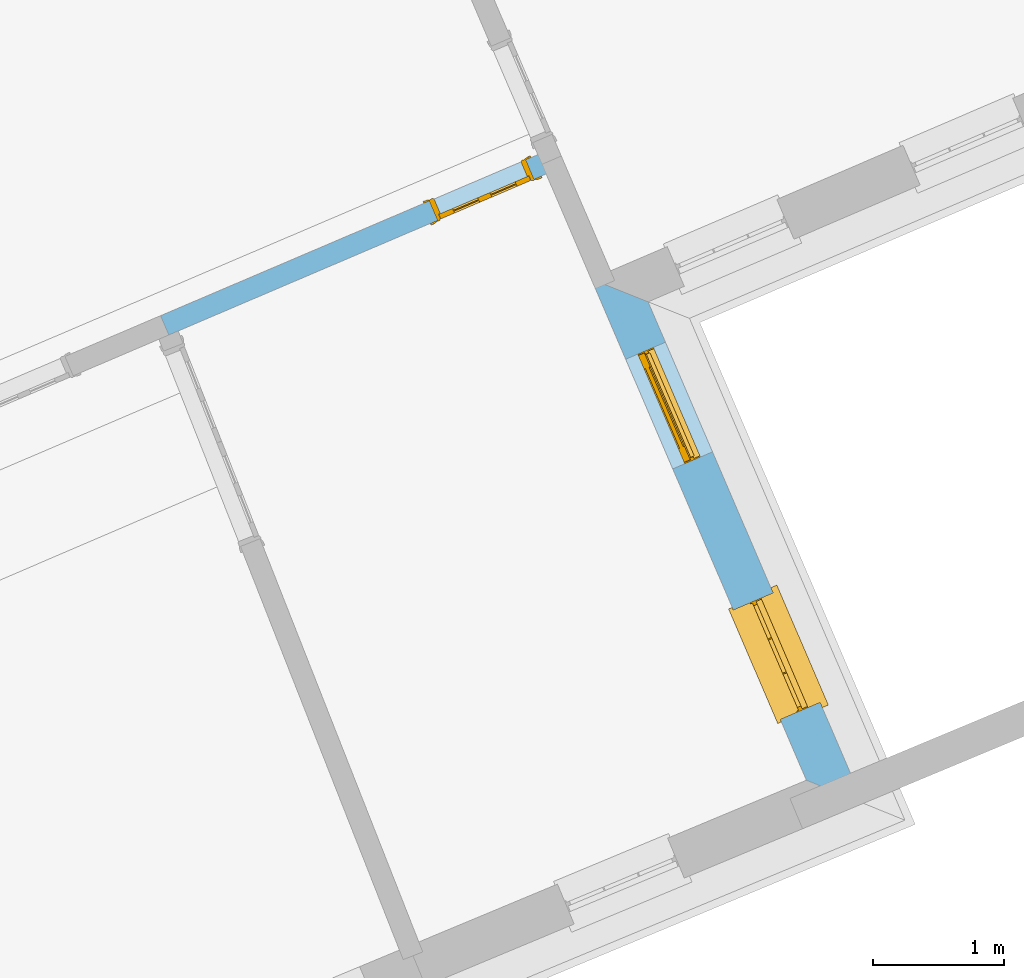
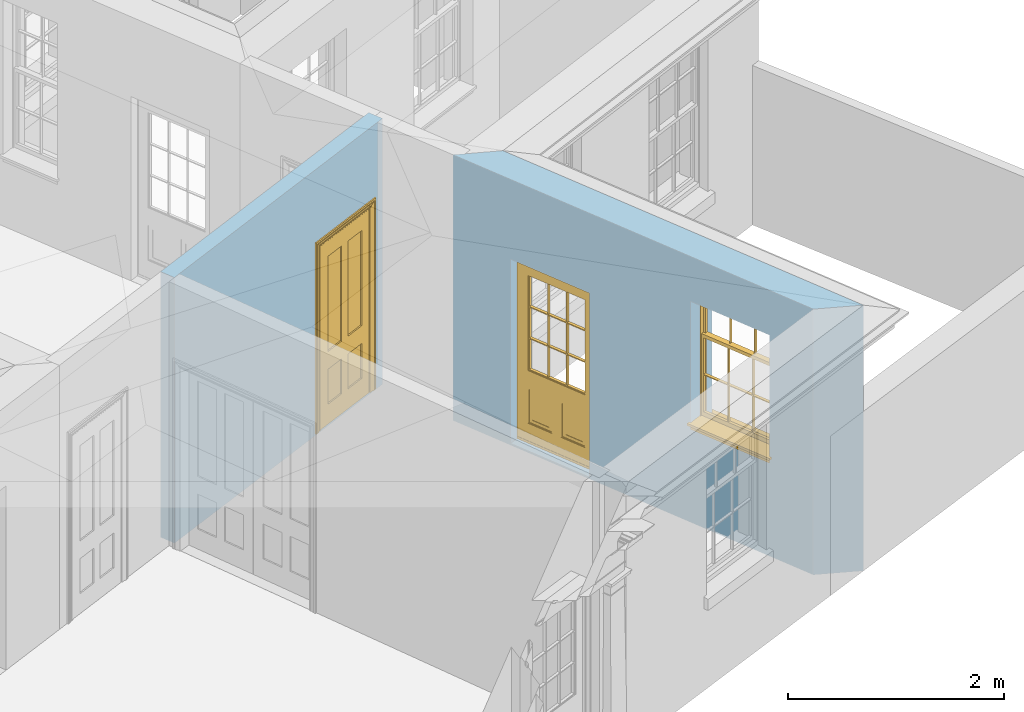
# One storey, part 8 of 19: 2 doors, 1 window, 3 openings, plus 2 elements that do not belong to this part.
"""IFC2X3 building model written with IfcOpenShell, lengths in metres."""

from ifc_helpers import new_model, si_unit, frame, origin, place, context, subcontext, project, spatial, polyline, outline, extrude, faceted_brep, material, layer, layer_set, layer_usage, element, fill, save


model = new_model("IFC2X3")

# Units and contexts
model_context = context("Model", 3, world=origin())
body_context = subcontext(model_context, "Body", "Model", "MODEL_VIEW")
ifc_project = project(units=[si_unit("PLANEANGLEUNIT", "RADIAN"), si_unit("MASSUNIT", "GRAM", prefix="KILO"), si_unit("FORCEUNIT", "NEWTON", prefix="KILO"), si_unit("LENGTHUNIT", "METRE")], contexts=[model_context])

# Site, building, storey
site_placement = place(None, origin())
site = spatial("IfcSite", under=ifc_project, at=site_placement, CompositionType="ELEMENT")
building_placement = place(None, origin())
building = spatial("IfcBuilding", under=site, at=building_placement, Name="Building plot-0", CompositionType="ELEMENT")
storey_placement = place(None, origin())
storey = spatial("IfcBuildingStorey", under=building, at=storey_placement, Name="Floor 0", CompositionType="ELEMENT", Elevation=0.0)

# Wall, openings, window, door
ifc_material_1 = material(Name="Masonry")
ifc_layer_1 = layer(ifc_material_1, 0.33, ventilated=False)
ifc_layer_set_1 = layer_set([ifc_layer_1], Name="My Wall")
ifc_layer_usage_1 = layer_usage(ifc_layer_set_1, "AXIS2", "NEGATIVE", 0.08)
wall_1_placement = place(storey_placement, origin())
wall_1 = element("IfcWallStandardCase", 1, at=wall_1_placement, inside=storey, material=ifc_layer_usage_1, Name="exterior", context=body_context, shape_type="SweptSolid", body=[
    extrude(outline(polyline([(24.2038471452139, 23.8554175583724), (24.6386025500617, 23.6792480885884), (22.9972229109118, 27.5025826875291), (22.5638042639667, 27.6756383909319), (24.2038471452139, 23.8554175583724)])), origin(), (0.0, 0.0, 1.0), 3.0),
])
opening_1_placement = place(storey_placement, frame((0.0, 0.0, 1.05)))
opening_1 = element("IfcOpeningElement", 2, at=opening_1_placement, cuts=wall_1, Name="Opening", ObjectType="Opening", context=body_context, shape_type="SweptSolid", body=[
    extrude(outline(polyline([(24.3083684269602, 24.4484763149473), (23.9493831563184, 25.2846757980027), (23.6461459811444, 25.1544943262315), (24.0051312517862, 24.3182948431761), (24.3083684269602, 24.4484763149473)])), origin(), (0.0, 0.0, 1.0), 1.445),
])
opening_2_placement = place(storey_placement, frame((0.0, 0.0, 0.02)))
opening_2 = element("IfcOpeningElement", 3, at=opening_2_placement, cuts=wall_1, Name="Opening", ObjectType="Opening", context=body_context, shape_type="SweptSolid", body=[
    extrude(outline(polyline([(23.4881849550756, 26.3589641574551), (23.1291996844338, 27.1951636405105), (22.8259625092599, 27.0649821687393), (23.1849477799017, 26.2287826856839), (23.4881849550756, 26.3589641574551)])), origin(), (0.0, 0.0, 1.0), 2.08),
])
window_placement = place(storey_placement, frame((24.0786432942526, 24.3498539878479, 1.05), z_axis=(0.0, 0.0, 1.0), x_axis=(-0.358985270641785, 0.836199483055474, 0.0)))
window = element("IfcWindow", 4, at=window_placement, inside=storey, Name="kitchen outside window", OverallHeight=1.445, OverallWidth=0.91, context=body_context, shape_type="Brep", held_by="IfcProductRepresentation", body=[
    faceted_brep([(0.876875, -0.105, 0.999097), (0.876875, -0.105, 1.411875), (0.9, -0.105, 1.435), (0.033125, -0.105, 1.411875), (0.033125, -0.105, 0.999097), (0.01, -0.105, 1.435), (0.033125, -0.135, 1.411875), (0.01, -0.135, 1.435), (0.033125, -0.135, 0.999097), (0.876875, -0.135, 1.411875), (0.876875, -0.135, 0.999097), (0.9, -0.135, 1.435), (0.033125, -0.105, 0.960972), (0.01, -0.105, 0.960972), (0.033125, -0.105, 0.548195), (0.876875, -0.105, 0.960972), (0.876875, -0.105, 0.548195), (0.9, -0.105, 0.960972), (0.876875, -0.105, 0.538195), (0.876875, -0.105, 0.125417), (0.9, -0.105, 0.077167), (0.033125, -0.105, 0.125417), (0.033125, -0.105, 0.538195), (0.01, -0.105, 0.077167), (0.9, -0.135, 0.960972), (0.01, -0.135, 0.960972), (-0.0425, -0.25, 0.01), (-0.0425, -0.3, 0.001667), (0.0, -0.25, 0.01), (0.9525, -0.25, 0.01), (0.91, -0.25, 0.01), (0.9525, -0.3, 0.001667), (-0.02, 0.08, 0.077167), (0.0, 0.08, 0.077167), (-0.02, 0.11, 0.077167), (0.0, -0.06, 0.077167), (0.01, -0.06, 0.077167), (0.91, -0.06, 0.077167), (0.91, 0.08, 0.077167), (0.9, -0.06, 0.077167), (0.93, 0.08, 0.077167), (0.93, 0.11, 0.077167), (0.01, -0.105, 0.999097), (0.01, -0.075, 0.999097), (0.9, -0.105, 0.999097), (0.9, -0.075, 0.999097), (0.876875, -0.075, 0.125417), (0.876875, -0.075, 0.538195), (0.9, -0.075, 0.077167), (0.876875, -0.075, 0.548195), (0.876875, -0.075, 0.960972), (0.033125, -0.075, 0.125417), (0.01, -0.075, 0.077167), (0.033125, -0.075, 0.538195), (0.033125, -0.075, 0.960972), (0.033125, -0.075, 0.548195), (-0.02, 0.08, 0.052167), (-0.02, 0.11, 0.052167), (0.93, 0.11, 0.052167), (0.93, 0.08, 0.052167), (0.91, 0.08, 0.052167), (0.0, 0.08, 0.052167), (0.91, -0.15, 0.026667), (0.0, -0.15, 0.026667), (-0.0425, -0.3, -0.123333), (0.9525, -0.3, -0.123333), (-0.0425, -0.25, -0.123333), (0.9525, -0.25, -0.123333), (0.01, -0.06, 1.435), (0.9, -0.06, 1.435), (0.0, -0.06, 1.445), (0.91, -0.06, 1.445), (0.01, -0.15, 0.077167), (0.9, -0.15, 0.077167), (0.592292, -0.105, 0.125417), (0.592292, -0.075, 0.125417), (0.317708, -0.075, 0.125417), (0.317708, -0.105, 0.125417), (0.592292, -0.105, 0.548195), (0.317708, -0.105, 0.548195), (0.317708, -0.105, 0.538195), (0.592292, -0.105, 0.538195), (0.592292, -0.075, 0.548195), (0.317708, -0.075, 0.548195), (0.602292, -0.075, 0.548195), (0.602292, -0.105, 0.548195), (0.317708, -0.075, 0.538195), (0.307708, -0.075, 0.125417), (0.307708, -0.075, 0.538195), (0.602292, -0.075, 0.538195), (0.602292, -0.075, 0.125417), (0.592292, -0.075, 0.538195), (0.307708, -0.075, 0.548195), (0.317708, -0.075, 0.960972), (0.307708, -0.075, 0.960972), (0.602292, -0.075, 0.960972), (0.592292, -0.075, 0.960972), (0.307708, -0.105, 0.538195), (0.307708, -0.105, 0.125417), (0.307708, -0.105, 0.548195), (0.307708, -0.105, 0.960972), (0.592292, -0.105, 0.960972), (0.317708, -0.105, 0.960972), (0.602292, -0.105, 0.960972), (0.602292, -0.105, 0.538195), (0.602292, -0.105, 0.125417), (0.317708, -0.135, 1.411875), (0.307708, -0.135, 1.411875), (0.307708, -0.135, 0.999097), (0.317708, -0.135, 0.999097), (0.602292, -0.135, 1.411875), (0.592292, -0.135, 1.411875), (0.592292, -0.135, 0.999097), (0.602292, -0.135, 0.999097), (0.317708, -0.105, 0.999097), (0.307708, -0.105, 0.999097), (0.307708, -0.105, 1.411875), (0.317708, -0.105, 1.411875), (0.602292, -0.105, 0.999097), (0.592292, -0.105, 0.999097), (0.592292, -0.105, 1.411875), (0.602292, -0.105, 1.411875), (0.91, -0.15, 1.445), (0.9, -0.15, 1.435), (0.01, -0.15, 1.435), (0.0, -0.15, 1.445), (0.91, -0.25, 0.0), (0.0, -0.25, 0.0), (0.91, 0.08, 0.0), (0.0, 0.08, 0.0)], [[[0, 1, 2]], [[3, 4, 5]], [[6, 7, 8]], [[9, 10, 11]], [[12, 13, 14]], [[15, 16, 17]], [[18, 19, 20]], [[21, 22, 23]], [[24, 15, 17]], [[13, 12, 25]], [[26, 27, 28]], [[29, 30, 31]], [[32, 33, 34]], [[35, 36, 33]], [[37, 38, 39]], [[40, 41, 38]], [[42, 4, 43]], [[44, 45, 0]], [[46, 47, 48]], [[49, 50, 45]], [[51, 52, 53]], [[54, 55, 43]], [[38, 33, 36, 39]], [[41, 34, 33, 38]], [[56, 32, 34, 57]], [[57, 34, 41, 58]], [[58, 41, 40, 59]], [[57, 58, 60, 61]], [[52, 48, 39, 36]], [[62, 63, 28, 30]], [[27, 31, 30, 28]], [[27, 64, 65, 31]], [[66, 67, 65, 64]], [[2, 5, 68, 69]], [[68, 70, 71, 69]], [[20, 23, 72, 73]], [[73, 72, 63, 62]], [[74, 75, 76, 77]], [[78, 79, 80, 81]], [[78, 82, 83, 79]], [[16, 49, 84, 85]], [[86, 76, 87, 88]], [[89, 90, 75, 91]], [[92, 88, 53, 55]], [[82, 91, 86, 83]], [[93, 83, 92, 94]], [[95, 84, 82, 96]], [[89, 84, 49, 47]], [[97, 88, 87, 98]], [[22, 53, 88, 97]], [[81, 91, 75, 74]], [[80, 86, 91, 81]], [[77, 76, 86, 80]], [[99, 92, 55, 14]], [[100, 94, 92, 99]], [[101, 96, 82, 78]], [[79, 83, 93, 102]], [[85, 84, 95, 103]], [[104, 89, 47, 18]], [[105, 90, 89, 104]], [[104, 18, 16, 85]], [[80, 97, 98, 77]], [[104, 81, 74, 105]], [[103, 101, 78, 85]], [[99, 14, 22, 97]], [[102, 100, 99, 79]], [[106, 107, 108, 109]], [[110, 111, 112, 113]], [[114, 115, 116, 117]], [[118, 119, 120, 121]], [[107, 116, 115, 108]], [[111, 120, 119, 112]], [[109, 114, 117, 106]], [[113, 118, 121, 110]], [[85, 78, 81, 104]], [[84, 89, 91, 82]], [[83, 86, 88, 92]], [[79, 99, 97, 80]], [[109, 112, 119, 114]], [[102, 93, 96, 101]], [[106, 117, 120, 111]], [[98, 87, 51, 21]], [[6, 3, 116, 107]], [[110, 121, 1, 9]], [[19, 46, 90, 105]], [[26, 66, 64, 27]], [[29, 31, 65, 67]], [[25, 24, 112, 109]], [[11, 7, 106, 111]], [[75, 48, 52, 76]], [[43, 45, 96, 93]], [[45, 43, 114, 119]], [[5, 2, 120, 117]], [[24, 25, 102, 101]], [[42, 5, 4]], [[2, 44, 0]], [[49, 45, 48, 47]], [[52, 43, 55, 53]], [[14, 13, 23, 22]], [[20, 17, 16, 18]], [[24, 11, 10]], [[25, 8, 7]], [[8, 4, 3, 6]], [[9, 1, 0, 10]], [[15, 50, 49, 16]], [[18, 47, 46, 19]], [[21, 51, 53, 22]], [[14, 55, 54, 12]], [[44, 2, 69, 45]], [[68, 5, 42, 43]], [[36, 35, 70, 68]], [[39, 69, 71, 37]], [[62, 122, 123, 73]], [[63, 72, 124, 125]], [[8, 108, 115, 4]], [[113, 10, 0, 118]], [[94, 100, 12, 54]], [[17, 20, 73, 24]], [[72, 23, 13, 25]], [[52, 36, 68, 43]], [[69, 39, 48, 45]], [[11, 24, 73, 123]], [[7, 124, 72, 25]], [[23, 77, 98]], [[98, 21, 23]], [[105, 74, 20]], [[20, 19, 105]], [[20, 74, 77, 23]], [[113, 112, 24]], [[24, 10, 113]], [[25, 109, 108]], [[108, 8, 25]], [[110, 9, 11]], [[11, 111, 110]], [[7, 6, 107]], [[107, 106, 7]], [[5, 117, 116]], [[116, 3, 5]], [[121, 120, 2]], [[2, 1, 121]], [[11, 123, 124, 7]], [[122, 125, 124, 123]], [[43, 93, 94]], [[94, 54, 43]], [[96, 45, 95]], [[50, 95, 45]], [[15, 103, 95, 50]], [[48, 75, 90]], [[90, 46, 48]], [[87, 76, 52]], [[52, 51, 87]], [[103, 15, 24]], [[24, 101, 103]], [[100, 102, 25]], [[25, 12, 100]], [[115, 114, 43]], [[43, 4, 115]], [[118, 0, 45]], [[45, 119, 118]], [[71, 70, 125, 122]], [[70, 35, 63, 125]], [[122, 62, 37, 71]], [[126, 67, 66, 127]], [[60, 58, 59]], [[38, 60, 59, 40]], [[61, 56, 57]], [[32, 56, 61, 33]], [[61, 60, 128, 129]], [[62, 60, 38, 37]], [[126, 128, 60, 62]], [[33, 61, 63, 35]], [[61, 129, 127, 63]], [[128, 126, 127, 129]], [[28, 127, 66, 26]], [[63, 127, 28]], [[29, 67, 126, 30]], [[30, 126, 62]]]),
])
fill(opening_1, window)
door_1_placement = place(storey_placement, frame((23.2584598223681, 26.2603418303557, 0.02), z_axis=(0.0, 0.0, 1.0), x_axis=(-0.358985270641785, 0.836199483055474, 0.0)))
door_1 = element("IfcDoor", 5, at=door_1_placement, inside=storey, Name="kitchen outside door", OverallHeight=2.08, OverallWidth=0.91, context=body_context, shape_type="Brep", held_by="IfcProductRepresentation", body=[
    faceted_brep([(0.545, -0.055, 0.265), (0.745, -0.055, 0.265), (0.745, -0.05, 0.265), (0.545, -0.05, 0.265), (0.745, -0.05, 0.58), (0.545, -0.05, 0.58), (0.545, -0.055, 0.58), (0.515, -0.06, 0.235), (0.775, -0.06, 0.235), (0.745, -0.055, 0.58), (0.515, -0.06, 0.61), (0.515, -0.065, 0.235), (0.775, -0.065, 0.235), (0.775, -0.06, 0.61), (0.515, -0.065, 0.61), (0.785, -0.065, 0.225), (0.505, -0.065, 0.225), (0.775, -0.065, 0.61), (0.505, -0.065, 0.62), (0.785, -0.065, 0.62), (0.505, -0.07, 0.225), (0.785, -0.07, 0.225), (0.505, -0.07, 0.62), (0.785, -0.07, 0.62), (0.883, -0.07, 0.075), (0.898, -0.07, 0.075), (0.405, -0.07, 0.62), (0.405, -0.07, 0.225), (0.027, -0.07, 0.075), (0.785, -0.07, 0.82), (0.125, -0.07, 0.82), (0.405, -0.065, 0.62), (0.405, -0.065, 0.225), (0.898, -0.07, 2.068), (0.027, -0.08, 0.075), (0.883, -0.08, 0.075), (0.125, -0.07, 0.225), (0.012, -0.07, 0.075), (0.785, -0.06, 0.82), (0.125, -0.06, 0.82), (0.125, -0.07, 0.62), (0.125, -0.065, 0.62), (0.395, -0.065, 0.61), (0.395, -0.065, 0.235), (0.125, -0.065, 0.225), (0.785, -0.07, 1.895), (0.027, -0.11, 0.045), (0.883, -0.11, 0.045), (0.558333, -0.06, 0.83), (0.351667, -0.06, 0.83), (0.125, -0.07, 1.895), (0.125, -0.06, 1.895), (0.785, -0.06, 1.895), (0.012, -0.07, 2.068), (0.135, -0.065, 0.61), (0.395, -0.06, 0.61), (0.395, -0.06, 0.235), (0.135, -0.065, 0.235), (0.027, -0.11, 0.027), (0.883, -0.11, 0.027), (0.568333, -0.06, 0.83), (0.558333, -0.03, 0.83), (0.351667, -0.03, 0.83), (0.341667, -0.06, 0.83), (0.135, -0.06, 1.185), (0.135, -0.06, 1.53), (0.775, -0.06, 1.53), (0.775, -0.06, 1.185), (0.135, -0.06, 0.61), (0.365, -0.055, 0.58), (0.365, -0.055, 0.265), (0.135, -0.06, 0.235), (0.568333, -0.06, 1.175), (0.558333, -0.06, 1.175), (0.775, -0.06, 0.83), (0.558333, -0.03, 1.175), (0.785, -0.03, 0.82), (0.125, -0.03, 0.82), (0.351667, -0.03, 1.175), (0.351667, -0.06, 1.175), (0.341667, -0.06, 1.175), (0.135, -0.06, 0.83), (0.135, -0.06, 1.175), (0.135, -0.03, 1.185), (0.135, -0.03, 1.53), (0.135, -0.06, 1.54), (0.351667, -0.06, 1.885), (0.558333, -0.06, 1.885), (0.775, -0.03, 1.53), (0.775, -0.03, 1.185), (0.775, -0.06, 1.175), (0.775, -0.06, 1.54), (0.165, -0.055, 0.58), (0.365, -0.05, 0.58), (0.365, -0.05, 0.265), (0.165, -0.055, 0.265), (0.568333, -0.03, 0.83), (0.568333, -0.03, 1.175), (0.568333, -0.06, 1.185), (0.558333, -0.06, 1.185), (0.775, -0.03, 0.83), (0.785, -0.02, 0.82), (0.125, -0.02, 0.82), (0.341667, -0.03, 0.83), (0.341667, -0.03, 1.175), (0.351667, -0.06, 1.185), (0.341667, -0.06, 1.185), (0.135, -0.03, 0.83), (0.341667, -0.03, 1.185), (0.125, -0.03, 1.895), (0.341667, -0.03, 1.53), (0.341667, -0.06, 1.53), (0.135, -0.06, 1.885), (0.341667, -0.06, 1.54), (0.341667, -0.06, 1.885), (0.558333, -0.03, 1.885), (0.351667, -0.03, 1.885), (0.568333, -0.06, 1.885), (0.785, -0.03, 1.895), (0.568333, -0.03, 1.185), (0.568333, -0.06, 1.53), (0.568333, -0.03, 1.53), (0.568333, -0.06, 1.54), (0.775, -0.06, 1.885), (0.165, -0.05, 0.58), (0.165, -0.05, 0.265), (0.775, -0.03, 1.175), (0.558333, -0.06, 1.53), (0.351667, -0.03, 1.185), (0.558333, -0.03, 1.185), (0.505, -0.02, 0.62), (0.405, -0.02, 0.62), (0.125, -0.02, 1.895), (0.785, -0.02, 1.895), (0.351667, -0.06, 1.53), (0.135, -0.03, 1.175), (0.135, -0.03, 1.54), (0.341667, -0.03, 1.54), (0.135, -0.03, 1.885), (0.351667, -0.06, 1.54), (0.558333, -0.03, 1.54), (0.558333, -0.06, 1.54), (0.351667, -0.03, 1.54), (0.775, -0.03, 1.54), (0.568333, -0.03, 1.54), (0.775, -0.03, 1.885), (0.558333, -0.03, 1.53), (0.405, -0.02, 0.225), (0.505, -0.02, 0.225), (0.125, -0.02, 0.62), (0.785, -0.02, 0.62), (0.012, -0.02, 2.068), (0.898, -0.02, 2.068), (0.351667, -0.03, 1.53), (0.341667, -0.03, 1.885), (0.568333, -0.03, 1.885), (0.405, -0.025, 0.225), (0.405, -0.025, 0.62), (0.505, -0.025, 0.62), (0.505, -0.025, 0.225), (0.898, -0.02, 0.027), (0.012, -0.02, 0.027), (0.125, -0.025, 0.62), (0.785, -0.025, 0.62), (0.395, -0.025, 0.235), (0.395, -0.025, 0.61), (0.125, -0.02, 0.225), (0.125, -0.025, 0.225), (0.515, -0.025, 0.61), (0.515, -0.025, 0.235), (0.785, -0.02, 0.225), (0.785, -0.025, 0.225), (0.135, -0.025, 0.61), (0.775, -0.025, 0.61), (0.135, -0.025, 0.235), (0.395, -0.03, 0.235), (0.395, -0.03, 0.61), (0.515, -0.03, 0.61), (0.515, -0.03, 0.235), (0.775, -0.025, 0.235), (0.135, -0.03, 0.61), (0.775, -0.03, 0.61), (0.135, -0.03, 0.235), (0.365, -0.035, 0.265), (0.365, -0.035, 0.58), (0.545, -0.035, 0.58), (0.545, -0.035, 0.265), (0.775, -0.03, 0.235), (0.165, -0.035, 0.58), (0.745, -0.035, 0.58), (0.165, -0.035, 0.265), (0.365, -0.04, 0.58), (0.365, -0.04, 0.265), (0.545, -0.04, 0.58), (0.545, -0.04, 0.265), (0.745, -0.035, 0.265), (0.165, -0.04, 0.58), (0.745, -0.04, 0.58), (0.165, -0.04, 0.265), (0.745, -0.04, 0.265), (0.885, -0.072, 0.025), (0.025, -0.072, 0.025), (0.025, -0.1, 0.025), (0.885, -0.1, 0.025), (0.9, -0.02, 0.025), (0.01, -0.02, 0.025), (0.9, -0.072, 0.025), (0.91, -0.02, 0.0), (0.0, -0.02, 0.0), (0.01, -0.072, 0.025), (0.9, -0.072, 2.07), (0.9, -0.02, 2.07), (0.885, -0.072, 2.055), (0.91, -0.02, 2.08), (0.01, -0.02, 2.07), (0.0, -0.02, 2.08), (0.01, -0.072, 2.07), (0.025, -0.072, 2.055), (0.0, -0.15, 2.08), (0.91, -0.15, 2.08), (0.01, -0.15, 2.07), (0.9, -0.15, 2.07), (0.01, -0.1, 2.07), (0.9, -0.1, 2.07), (0.0, -0.15, 0.0), (0.91, -0.15, 0.0), (0.01, -0.15, 0.025), (0.9, -0.15, 0.025), (0.01, -0.1, 0.025), (0.025, -0.1, 2.055), (0.9, -0.1, 0.025), (0.885, -0.1, 2.055), (0.898, -0.07, 0.027), (0.012, -0.07, 0.027), (0.883, -0.07, 0.027), (0.027, -0.07, 0.027)], [[[0, 1, 2, 3]], [[2, 4, 5, 3]], [[0, 3, 5, 6]], [[1, 0, 7, 8]], [[9, 4, 2, 1]], [[9, 6, 5, 4]], [[0, 6, 10, 7]], [[8, 7, 11, 12]], [[8, 13, 9, 1]], [[13, 10, 6, 9]], [[7, 10, 14, 11]], [[15, 12, 11, 16]], [[12, 17, 13, 8]], [[17, 14, 10, 13]], [[18, 16, 11, 14]], [[15, 19, 17, 12]], [[15, 16, 20, 21]], [[14, 17, 19, 18]], [[16, 18, 22, 20]], [[21, 23, 19, 15]], [[24, 25, 21, 20]], [[23, 22, 18, 19]], [[20, 22, 26, 27]], [[23, 21, 25]], [[28, 24, 20, 27]], [[22, 23, 29]], [[29, 30, 26, 22]], [[27, 26, 31, 32]], [[23, 25, 33, 29]], [[34, 35, 24, 28]], [[28, 27, 36, 37]], [[38, 39, 30, 29]], [[26, 30, 40]], [[26, 40, 41, 31]], [[42, 43, 32, 31]], [[32, 44, 36, 27]], [[33, 45, 29]], [[46, 47, 35, 34]], [[36, 40, 37]], [[39, 38, 48, 49]], [[50, 30, 39, 51]], [[29, 45, 52, 38]], [[53, 37, 40, 30]], [[44, 41, 40, 36]], [[31, 41, 54, 42]], [[43, 42, 55, 56]], [[57, 44, 32, 43]], [[50, 45, 33, 53]], [[47, 46, 58, 59]], [[60, 48, 38]], [[49, 48, 61, 62]], [[49, 63, 39]], [[50, 53, 30]], [[51, 39, 64, 65]], [[45, 50, 51, 52]], [[66, 67, 38, 52]], [[57, 54, 41, 44]], [[42, 54, 68, 55]], [[56, 55, 69, 70]], [[56, 71, 57, 43]], [[60, 72, 73, 48]], [[60, 38, 74]], [[48, 73, 75, 61]], [[76, 77, 62, 61]], [[62, 78, 79, 49]], [[49, 79, 80, 63]], [[63, 81, 39]], [[82, 64, 39]], [[65, 64, 83, 84]], [[85, 51, 65]], [[52, 51, 86, 87]], [[88, 89, 67, 66]], [[90, 38, 67]], [[91, 66, 52]], [[71, 68, 54, 57]], [[55, 68, 92, 69]], [[69, 93, 94, 70]], [[70, 95, 71, 56]], [[96, 97, 72, 60]], [[73, 72, 98, 99]], [[74, 38, 90]], [[100, 96, 60, 74]], [[75, 73, 79, 78]], [[61, 75, 97, 96]], [[101, 102, 77, 76]], [[77, 103, 62]], [[96, 76, 61]], [[103, 104, 78, 62]], [[80, 79, 105, 106]], [[63, 80, 104, 103]], [[81, 63, 103, 107]], [[81, 82, 39]], [[106, 64, 82, 80]], [[106, 108, 83, 64]], [[84, 83, 77, 109]], [[110, 111, 65, 84]], [[112, 51, 85]], [[113, 85, 65, 111]], [[114, 86, 51]], [[115, 87, 86, 116]], [[117, 52, 87]], [[118, 76, 89, 88]], [[119, 98, 67, 89]], [[120, 121, 88, 66]], [[67, 98, 72, 90]], [[91, 122, 120, 66]], [[91, 52, 123]], [[95, 92, 68, 71]], [[69, 92, 124, 93]], [[94, 93, 124, 125]], [[94, 125, 95, 70]], [[72, 97, 126, 90]], [[127, 99, 98, 120]], [[99, 105, 79, 73]], [[74, 90, 126, 100]], [[96, 100, 76]], [[128, 129, 75, 78]], [[97, 75, 129, 119]], [[130, 131, 102, 101]], [[109, 77, 102, 132]], [[133, 101, 76, 118]], [[77, 107, 103]], [[78, 104, 108, 128]], [[111, 106, 105, 134]], [[104, 80, 82, 135]], [[107, 135, 82, 81]], [[110, 108, 106, 111]], [[104, 135, 83, 108]], [[83, 135, 77]], [[136, 84, 109]], [[110, 84, 136, 137]], [[114, 51, 112]], [[85, 136, 138, 112]], [[113, 137, 136, 85]], [[111, 134, 139, 113]], [[86, 114, 113, 139]], [[140, 141, 87, 115]], [[139, 142, 116, 86]], [[109, 118, 115, 116]], [[117, 123, 52]], [[117, 87, 141, 122]], [[126, 89, 76]], [[143, 118, 88]], [[120, 98, 119, 121]], [[119, 89, 126, 97]], [[144, 143, 88, 121]], [[144, 122, 91, 143]], [[127, 120, 122, 141]], [[143, 91, 123, 145]], [[124, 92, 95, 125]], [[146, 129, 99, 127]], [[99, 129, 128, 105]], [[100, 126, 76]], [[121, 119, 129, 146]], [[147, 131, 130, 148]], [[131, 149, 102]], [[130, 101, 150]], [[102, 151, 132]], [[118, 109, 132, 133]], [[101, 133, 152]], [[107, 77, 135]], [[153, 128, 108, 110]], [[134, 105, 128, 153]], [[109, 138, 136]], [[153, 110, 137, 142]], [[154, 114, 112, 138]], [[137, 113, 114, 154]], [[141, 139, 134, 127]], [[141, 140, 142, 139]], [[144, 140, 115, 155]], [[142, 137, 154, 116]], [[155, 115, 118]], [[116, 154, 109]], [[117, 155, 145, 123]], [[122, 144, 155, 117]], [[143, 145, 118]], [[121, 146, 140, 144]], [[146, 127, 134, 153]], [[156, 157, 131, 147]], [[148, 130, 158, 159]], [[148, 160, 161, 147]], [[157, 162, 149, 131]], [[161, 151, 102, 149]], [[101, 152, 160, 150]], [[163, 158, 130, 150]], [[151, 152, 133, 132]], [[154, 138, 109]], [[142, 140, 146, 153]], [[145, 155, 118]], [[157, 156, 164, 165]], [[147, 166, 167, 156]], [[168, 169, 159, 158]], [[170, 148, 159, 171]], [[148, 170, 160]], [[166, 147, 161]], [[172, 162, 157, 165]], [[166, 149, 162, 167]], [[166, 161, 149]], [[150, 160, 170]], [[163, 173, 168, 158]], [[171, 163, 150, 170]], [[174, 164, 156, 167]], [[175, 176, 165, 164]], [[169, 168, 177, 178]], [[171, 159, 169, 179]], [[167, 162, 172, 174]], [[176, 180, 172, 165]], [[179, 173, 163, 171]], [[181, 177, 168, 173]], [[164, 174, 182, 175]], [[183, 184, 176, 175]], [[178, 177, 185, 186]], [[179, 169, 178, 187]], [[174, 172, 180, 182]], [[184, 188, 180, 176]], [[187, 181, 173, 179]], [[189, 185, 177, 181]], [[175, 182, 190, 183]], [[191, 184, 183, 192]], [[185, 193, 194, 186]], [[187, 178, 186, 195]], [[182, 180, 188, 190]], [[191, 196, 188, 184]], [[195, 189, 181, 187]], [[197, 193, 185, 189]], [[183, 190, 198, 192]], [[198, 196, 191, 192]], [[194, 193, 197, 199]], [[195, 186, 194, 199]], [[188, 196, 198, 190]], [[197, 189, 195, 199]], [[200, 201, 202, 203]], [[201, 200, 204, 205]], [[206, 204, 200]], [[204, 207, 208, 205]], [[209, 201, 205]], [[210, 211, 204, 206]], [[206, 200, 212, 210]], [[211, 213, 207, 204]], [[214, 205, 208, 215]], [[216, 217, 201, 209]], [[205, 214, 216, 209]], [[216, 214, 211, 210]], [[210, 212, 217, 216]], [[214, 215, 213, 211]], [[218, 219, 213, 215]], [[219, 218, 220, 221]], [[221, 220, 222, 223]], [[215, 208, 224, 218]], [[225, 224, 208, 207]], [[224, 226, 220, 218]], [[224, 225, 227, 226]], [[219, 225, 207, 213]], [[228, 222, 220, 226]], [[219, 221, 227, 225]], [[226, 227, 203, 202]], [[202, 229, 222, 228]], [[228, 226, 202]], [[227, 221, 223, 230]], [[230, 203, 227]], [[217, 229, 202, 201]], [[231, 223, 222, 229]], [[230, 223, 231, 203]], [[231, 229, 217, 212]], [[212, 200, 203, 231]], [[33, 152, 151, 53]], [[25, 160, 152, 33]], [[161, 37, 53, 151]], [[232, 160, 25]], [[161, 233, 37]], [[160, 232, 234]], [[24, 234, 232, 25]], [[233, 161, 235]], [[37, 233, 235, 28]], [[161, 160, 234, 235]], [[35, 47, 234, 24]], [[28, 235, 46, 34]], [[58, 235, 234, 59]], [[59, 234, 47]], [[58, 46, 235]]]),
])
fill(opening_2, door_1)

# Wall, opening, door
ifc_material_2 = material(Name="Masonry")
ifc_layer_2 = layer(ifc_material_2, 0.16, ventilated=False)
ifc_layer_set_2 = layer_set([ifc_layer_2], Name="My Wall")
ifc_layer_usage_2 = layer_usage(ifc_layer_set_2, "AXIS2", "NEGATIVE", 0.08)
wall_2_placement = place(storey_placement, origin())
wall_2 = element("IfcWallStandardCase", 6, at=wall_2_placement, inside=storey, material=ifc_layer_usage_2, Name="interior", context=body_context, shape_type="SweptSolid", body=[
    extrude(outline(polyline([(22.2929838809625, 28.5088285315585), (22.2301825591953, 28.6559882882323), (19.2802656397847, 27.3970932898327), (19.3430669615519, 27.2499335331589), (22.2929838809625, 28.5088285315585)])), origin(), (0.0, 0.0, 1.0), 3.0),
])
opening_3_placement = place(storey_placement, frame((0.0, 0.0, 0.02)))
opening_3 = element("IfcOpeningElement", 7, at=opening_3_placement, cuts=wall_2, Name="Opening", ObjectType="Opening", context=body_context, shape_type="SweptSolid", body=[
    extrude(outline(polyline([(22.0646278329373, 28.5853368012442), (21.3288290495682, 28.2713301924083), (21.3916303713354, 28.1241704357345), (22.1274291547045, 28.4381770445704), (22.0646278329373, 28.5853368012442)])), origin(), (0.0, 0.0, 1.0), 2.1),
])
door_2_placement = place(storey_placement, frame((22.0960284938209, 28.5117569229073, 0.02), z_axis=(0.0, 0.0, 1.0), x_axis=(-0.735798783369045, -0.314006608835914, 0.0)))
door_2 = element("IfcDoor", 8, at=door_2_placement, inside=storey, Name="kitchen inside door", OverallHeight=2.1, OverallWidth=0.8, context=body_context, shape_type="Brep", held_by="IfcProductRepresentation", body=[
    faceted_brep([(0.773, 0.08, 1.895), (0.66, 0.08, 1.895), (0.66, 0.08, 2.073), (0.773, 0.08, 2.073), (0.773, 0.08, 0.82), (0.66, 0.08, 0.82), (0.45, 0.08, 1.895), (0.45, 0.08, 2.073), (0.773, 0.08, 0.62), (0.66, 0.08, 0.62), (0.66, 0.065, 0.82), (0.66, 0.065, 1.895), (0.45, 0.065, 1.895), (0.35, 0.08, 1.895), (0.35, 0.08, 2.073), (0.773, 0.08, 0.225), (0.66, 0.08, 0.225), (0.45, 0.08, 0.62), (0.45, 0.08, 0.82), (0.45, 0.065, 0.82), (0.35, 0.08, 0.82), (0.14, 0.08, 2.073), (0.14, 0.08, 1.895), (0.773, 0.08, 0.0), (0.66, 0.08, 0.0), (0.66, 0.065, 0.225), (0.66, 0.065, 0.62), (0.45, 0.065, 0.62), (0.35, 0.08, 0.62), (0.35, 0.065, 0.82), (0.35, 0.065, 1.895), (0.14, 0.065, 1.895), (0.027, 0.08, 2.073), (0.027, 0.08, 1.895), (0.773, 0.042, 0.0), (0.66, 0.042, 0.0), (0.45, 0.08, 0.0), (0.45, 0.08, 0.225), (0.45, 0.065, 0.225), (0.35, 0.08, 0.225), (0.14, 0.08, 0.82), (0.14, 0.08, 0.62), (0.14, 0.065, 0.82), (0.027, 0.08, 0.82), (0.773, 0.042, 0.225), (0.66, 0.042, 0.225), (0.45, 0.042, 0.0), (0.35, 0.08, 0.0), (0.35, 0.065, 0.225), (0.35, 0.065, 0.62), (0.14, 0.065, 0.62), (0.027, 0.08, 0.62), (0.773, 0.042, 0.62), (0.66, 0.042, 0.62), (0.45, 0.042, 0.225), (0.35, 0.042, 0.0), (0.14, 0.08, 0.225), (0.14, 0.08, 0.0), (0.14, 0.065, 0.225), (0.027, 0.08, 0.225), (0.773, 0.042, 0.82), (0.66, 0.042, 0.82), (0.66, 0.057, 0.62), (0.66, 0.057, 0.225), (0.45, 0.057, 0.225), (0.35, 0.042, 0.225), (0.14, 0.042, 0.0), (0.027, 0.08, 0.0), (0.773, 0.042, 1.895), (0.66, 0.042, 1.895), (0.45, 0.042, 0.62), (0.45, 0.042, 0.82), (0.45, 0.057, 0.62), (0.35, 0.042, 0.62), (0.14, 0.042, 0.225), (0.027, 0.042, 0.0), (0.773, 0.042, 2.073), (0.66, 0.042, 2.073), (0.66, 0.057, 1.895), (0.66, 0.057, 0.82), (0.45, 0.057, 0.82), (0.35, 0.042, 0.82), (0.35, 0.057, 0.62), (0.35, 0.057, 0.225), (0.14, 0.057, 0.225), (0.027, 0.042, 0.225), (0.45, 0.042, 1.895), (0.45, 0.042, 2.073), (0.45, 0.057, 1.895), (0.35, 0.042, 1.895), (0.14, 0.042, 0.82), (0.14, 0.042, 0.62), (0.14, 0.057, 0.62), (0.027, 0.042, 0.62), (0.35, 0.042, 2.073), (0.35, 0.057, 1.895), (0.35, 0.057, 0.82), (0.14, 0.057, 0.82), (0.027, 0.042, 0.82), (0.14, 0.042, 2.073), (0.14, 0.042, 1.895), (0.14, 0.057, 1.895), (0.027, 0.042, 1.895), (0.027, 0.042, 2.073), (0.02, 0.085, 0.0), (0.005, 0.09, 0.0), (0.005, 0.09, 2.095), (0.02, 0.085, 2.08), (0.02, 0.08, 0.0), (0.0, 0.085, 0.0), (0.0, 0.085, 2.1), (0.795, 0.09, 2.095), (0.78, 0.085, 2.08), (0.02, 0.08, 2.08), (0.0, 0.08, 0.0), (-0.032, 0.095, 0.0), (-0.032, 0.095, 2.132), (0.8, 0.085, 2.1), (0.795, 0.09, 0.0), (0.78, 0.085, 0.0), (0.78, 0.08, 2.08), (0.04, 0.04, 0.0), (0.025, 0.04, 0.0), (0.025, 0.04, 2.075), (0.04, 0.04, 2.06), (-0.04, 0.09, 0.0), (-0.04, 0.09, 2.14), (0.832, 0.095, 2.132), (0.8, 0.085, 0.0), (0.78, 0.08, 0.0), (0.8, 0.08, 0.0), (0.86, 0.08, 0.0), (0.86, 0.08, 2.16), (0.8, 0.08, 2.1), (-0.06, 0.08, 2.16), (0.0, 0.08, 2.1), (-0.06, 0.08, 0.0), (-0.04, 0.095, 0.0), (-0.04, 0.095, 2.14), (0.84, 0.09, 2.14), (0.832, 0.095, 0.0), (0.84, 0.09, 0.0), (0.86, 0.095, 0.0), (0.86, 0.095, 2.16), (-0.06, 0.095, 2.16), (-0.06, 0.095, 0.0), (0.84, 0.095, 0.0), (0.84, 0.095, 2.14), (-0.025, -0.095, 0.0), (-0.025, -0.09, 0.0), (-0.025, -0.09, 2.125), (-0.025, -0.095, 2.125), (-0.017, -0.095, 0.0), (-0.017, -0.095, 2.117), (0.825, -0.09, 2.125), (0.825, -0.095, 2.125), (0.825, -0.095, 0.0), (0.845, -0.095, 0.0), (-0.045, -0.095, 2.145), (-0.045, -0.095, 0.0), (0.845, -0.095, 2.145), (0.015, -0.085, 0.0), (0.015, -0.085, 2.085), (0.817, -0.095, 2.117), (0.825, -0.09, 0.0), (0.845, -0.08, 0.0), (0.845, -0.08, 2.145), (-0.045, -0.08, 2.145), (-0.045, -0.08, 0.0), (0.02, -0.09, 0.0), (0.02, -0.09, 2.08), (0.785, -0.085, 2.085), (0.817, -0.095, 0.0), (0.8, -0.08, 0.0), (0.8, -0.08, 2.1), (0.0, -0.08, 2.1), (0.0, -0.08, 0.0), (0.035, -0.085, 0.0), (0.035, -0.085, 2.065), (0.78, -0.09, 2.08), (0.785, -0.085, 0.0), (0.775, 0.04, 2.075), (0.76, 0.04, 2.06), (0.035, -0.08, 2.065), (0.035, -0.08, 0.0), (0.765, -0.085, 2.065), (0.78, -0.09, 0.0), (0.765, -0.08, 0.0), (0.765, -0.08, 2.065), (0.765, -0.085, 0.0), (0.04, -0.08, 2.06), (0.04, -0.08, 0.0), (0.76, -0.08, 2.06), (0.76, -0.08, 0.0), (0.76, 0.04, 0.0), (0.775, 0.04, 0.0), (0.025, 0.08, 0.0), (0.025, 0.08, 2.075), (0.775, 0.08, 0.0), (0.775, 0.08, 2.075)], [[[0, 1, 2, 3]], [[1, 0, 4, 5]], [[1, 6, 7, 2]], [[8, 9, 5, 4]], [[1, 5, 10, 11]], [[6, 1, 11, 12]], [[6, 13, 14, 7]], [[15, 16, 9, 8]], [[9, 17, 18, 5]], [[5, 18, 19, 10]], [[10, 19, 12, 11]], [[18, 6, 12, 19]], [[18, 20, 13, 6]], [[21, 14, 13, 22]], [[23, 24, 16, 15]], [[9, 16, 25, 26]], [[17, 9, 26, 27]], [[17, 28, 20, 18]], [[13, 20, 29, 30]], [[22, 13, 30, 31]], [[32, 21, 22, 33]], [[34, 35, 24, 23]], [[24, 36, 37, 16]], [[16, 37, 38, 25]], [[25, 38, 27, 26]], [[37, 17, 27, 38]], [[37, 39, 28, 17]], [[40, 20, 28, 41]], [[20, 40, 42, 29]], [[31, 30, 29, 42]], [[40, 22, 31, 42]], [[33, 22, 40, 43]], [[35, 34, 44, 45]], [[35, 46, 36, 24]], [[36, 47, 39, 37]], [[28, 39, 48, 49]], [[41, 28, 49, 50]], [[43, 40, 41, 51]], [[45, 44, 52, 53]], [[46, 35, 45, 54]], [[46, 55, 47, 36]], [[56, 39, 47, 57]], [[39, 56, 58, 48]], [[50, 49, 48, 58]], [[56, 41, 50, 58]], [[51, 41, 56, 59]], [[53, 52, 60, 61]], [[45, 53, 62, 63]], [[54, 45, 63, 64]], [[55, 46, 54, 65]], [[55, 66, 57, 47]], [[59, 56, 57, 67]], [[61, 60, 68, 69]], [[70, 53, 61, 71]], [[53, 70, 72, 62]], [[72, 64, 63, 62]], [[70, 54, 64, 72]], [[65, 54, 70, 73]], [[65, 74, 66, 55]], [[67, 57, 66, 75]], [[69, 68, 76, 77]], [[61, 69, 78, 79]], [[71, 61, 79, 80]], [[73, 70, 71, 81]], [[65, 73, 82, 83]], [[74, 65, 83, 84]], [[74, 85, 75, 66]], [[86, 69, 77, 87]], [[69, 86, 88, 78]], [[88, 80, 79, 78]], [[86, 71, 80, 88]], [[81, 71, 86, 89]], [[73, 81, 90, 91]], [[73, 91, 92, 82]], [[83, 82, 92, 84]], [[91, 74, 84, 92]], [[91, 93, 85, 74]], [[89, 86, 87, 94]], [[81, 89, 95, 96]], [[90, 81, 96, 97]], [[90, 98, 93, 91]], [[94, 99, 100, 89]], [[89, 100, 101, 95]], [[101, 97, 96, 95]], [[100, 90, 97, 101]], [[100, 102, 98, 90]], [[99, 103, 102, 100]], [[32, 103, 99, 21]], [[102, 103, 32, 33]], [[98, 102, 33, 43]], [[21, 99, 94, 14]], [[94, 87, 7, 14]], [[7, 87, 77, 2]], [[76, 3, 2, 77]], [[43, 51, 93, 98]], [[51, 59, 85, 93]], [[67, 75, 85, 59]], [[34, 23, 15, 44]], [[44, 15, 8, 52]], [[52, 8, 4, 60]], [[0, 68, 60, 4]], [[0, 3, 76, 68]], [[104, 105, 106, 107]], [[104, 108, 109, 105]], [[105, 109, 110, 106]], [[107, 106, 111, 112]], [[107, 113, 108, 104]], [[114, 109, 108]], [[109, 115, 116, 110]], [[106, 110, 117, 111]], [[112, 111, 118, 119]], [[113, 107, 112, 120]], [[121, 122, 123, 124]], [[115, 109, 114, 125]], [[115, 125, 126, 116]], [[110, 116, 127, 117]], [[111, 117, 128, 118]], [[118, 128, 129, 119]], [[120, 112, 119, 129]], [[130, 129, 128]], [[130, 131, 132, 133]], [[133, 132, 134, 135]], [[135, 134, 136, 114]], [[136, 125, 114]], [[125, 137, 138, 126]], [[116, 126, 139, 127]], [[117, 127, 140, 128]], [[141, 130, 128, 140]], [[131, 130, 141]], [[131, 142, 143, 132]], [[132, 143, 144, 134]], [[134, 144, 145, 136]], [[137, 125, 136, 145]], [[143, 142, 146]], [[143, 146, 147]], [[137, 145, 144]], [[143, 147, 138]], [[138, 137, 144]], [[143, 138, 144]], [[126, 138, 147, 139]], [[127, 139, 141, 140]], [[142, 131, 141, 146]], [[139, 147, 146, 141]], [[148, 149, 150, 151]], [[149, 152, 153, 150]], [[151, 150, 154, 155]], [[155, 156, 157]], [[158, 159, 148]], [[158, 148, 151]], [[155, 157, 160]], [[158, 151, 155]], [[155, 160, 158]], [[152, 161, 162, 153]], [[150, 153, 163, 154]], [[155, 154, 164, 156]], [[156, 164, 165, 157]], [[157, 165, 166, 160]], [[160, 166, 167, 158]], [[158, 167, 168, 159]], [[161, 169, 170, 162]], [[153, 162, 171, 163]], [[154, 163, 172, 164]], [[165, 164, 173]], [[165, 173, 174, 166]], [[166, 174, 175, 167]], [[167, 175, 176, 168]], [[169, 177, 178, 170]], [[162, 170, 179, 171]], [[163, 171, 180, 172]], [[172, 180, 173, 164]], [[124, 123, 181, 182]], [[183, 178, 177, 184]], [[170, 178, 185, 179]], [[171, 179, 186, 180]], [[187, 173, 180]], [[185, 188, 187, 189]], [[188, 185, 178, 183]], [[179, 185, 189, 186]], [[189, 187, 180, 186]], [[190, 183, 184, 191]], [[192, 188, 183, 190]], [[191, 184, 122, 121]], [[124, 190, 191, 121]], [[193, 187, 188, 192]], [[182, 192, 190, 124]], [[184, 176, 122]], [[194, 195, 187, 193]], [[192, 182, 194, 193]], [[161, 176, 184]], [[114, 108, 122, 176]], [[173, 187, 195]], [[152, 149, 176, 161]], [[169, 161, 184, 177]], [[196, 122, 108]], [[176, 175, 135, 114]], [[173, 195, 129, 130]], [[176, 149, 168]], [[123, 122, 196, 197]], [[196, 108, 113, 197]], [[175, 174, 133, 135]], [[198, 129, 195]], [[133, 174, 173, 130]], [[159, 168, 149, 148]], [[181, 123, 197, 199]], [[197, 113, 120, 199]], [[199, 120, 129, 198]], [[195, 181, 199, 198]], [[195, 194, 182, 181]]]),
])
fill(opening_3, door_2)

save(model, "model.ifc")
